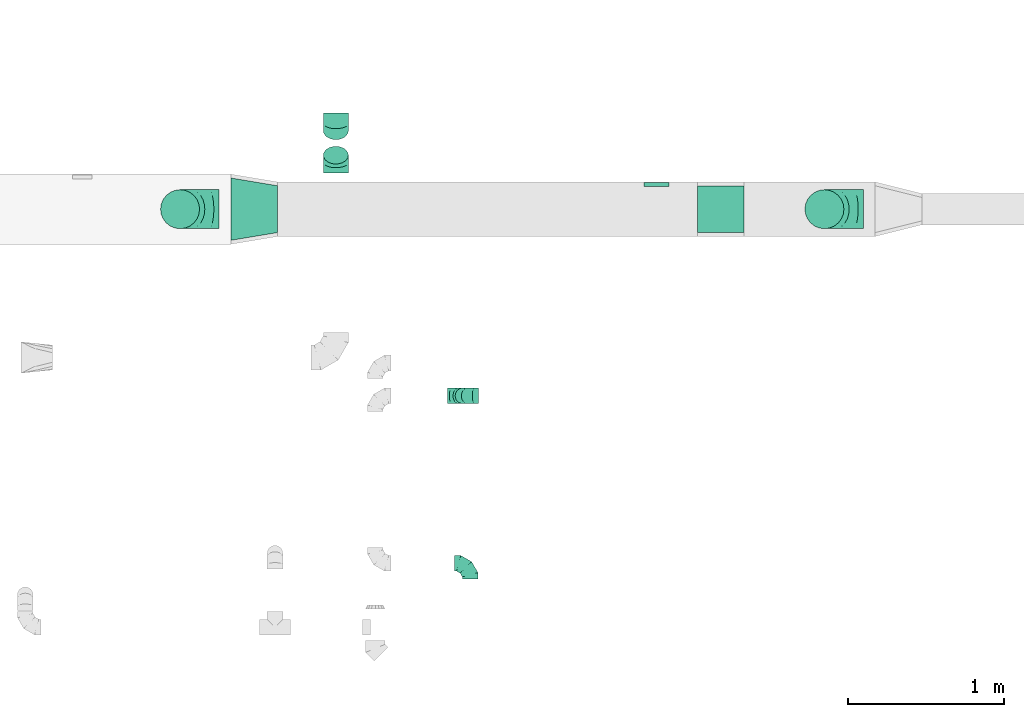
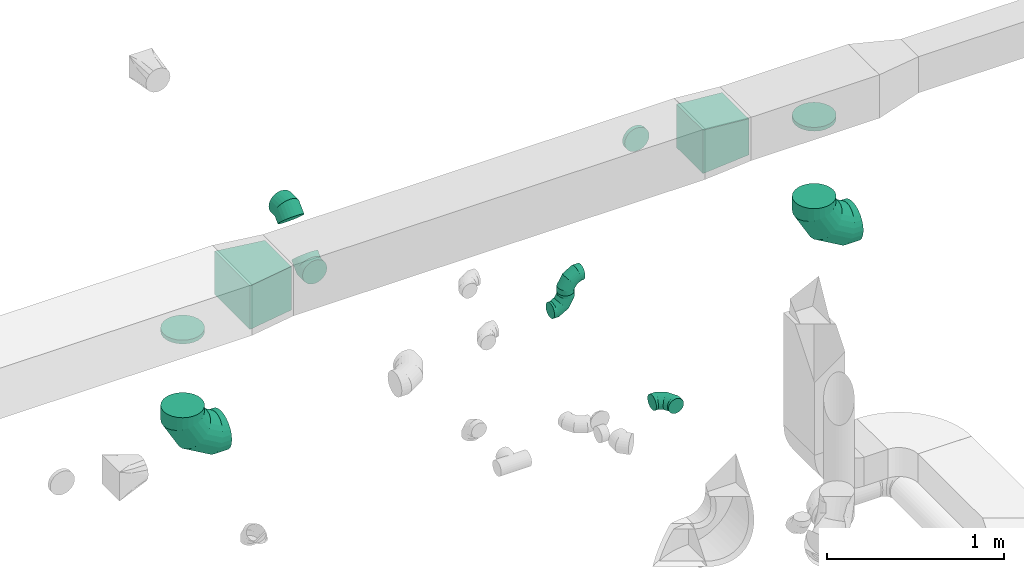
# One storey, part 70 of 97: 12 flow fittings.
"""IFC2X3 building model written with IfcOpenShell, lengths in millimetres."""

from ifc_helpers import new_model, entity, si_unit, converted_unit, derived_unit, direction, frame, origin, place, context, subcontext, project, spatial, polyline, outline, extrude, faceted_brep, source, transform, mapped, material, type_object, type_shapes, element, save


model = new_model("IFC2X3")

# Units and contexts
model_context = context("Model", 3, precision=0.01, world=origin(), true_north=direction((6.12303176911189e-17, 1.0)))
body_context = subcontext(model_context, "Body", "Model", "MODEL_VIEW")
ifc_project = project(units=[si_unit("LENGTHUNIT", "METRE", prefix="MILLI"), si_unit("AREAUNIT", "SQUARE_METRE"), si_unit("VOLUMEUNIT", "CUBIC_METRE"), converted_unit("PLANEANGLEUNIT", "DEGREE", entity("IfcRatioMeasure", 0.0174532925199433), si_unit("PLANEANGLEUNIT", "RADIAN"), dimensions=[0, 0, 0, 0, 0, 0, 0]), si_unit("MASSUNIT", "GRAM", prefix="KILO"), derived_unit("MASSDENSITYUNIT", [(si_unit("MASSUNIT", "GRAM", prefix="KILO"), 1), (si_unit("LENGTHUNIT", "METRE"), -3)]), derived_unit("MOMENTOFINERTIAUNIT", [(si_unit("LENGTHUNIT", "METRE"), 4)]), si_unit("TIMEUNIT", "SECOND"), si_unit("FREQUENCYUNIT", "HERTZ"), si_unit("THERMODYNAMICTEMPERATUREUNIT", "DEGREE_CELSIUS"), derived_unit("THERMALTRANSMITTANCEUNIT", [(si_unit("MASSUNIT", "GRAM", prefix="KILO"), 1), (si_unit("THERMODYNAMICTEMPERATUREUNIT", "KELVIN"), -1), (si_unit("TIMEUNIT", "SECOND"), -3)]), derived_unit("VOLUMETRICFLOWRATEUNIT", [(si_unit("LENGTHUNIT", "METRE"), 3), (si_unit("TIMEUNIT", "SECOND"), -1)]), derived_unit("MASSFLOWRATEUNIT", [(si_unit("MASSUNIT", "GRAM", prefix="KILO"), 1), (si_unit("TIMEUNIT", "SECOND"), -1)]), derived_unit("ROTATIONALFREQUENCYUNIT", [(si_unit("TIMEUNIT", "SECOND"), -1)]), si_unit("ELECTRICCURRENTUNIT", "AMPERE"), si_unit("ELECTRICVOLTAGEUNIT", "VOLT"), si_unit("POWERUNIT", "WATT"), si_unit("FORCEUNIT", "NEWTON", prefix="KILO"), si_unit("ILLUMINANCEUNIT", "LUX"), si_unit("LUMINOUSFLUXUNIT", "LUMEN"), si_unit("LUMINOUSINTENSITYUNIT", "CANDELA"), derived_unit("USERDEFINED", [(si_unit("MASSUNIT", "GRAM", prefix="KILO"), -1), (si_unit("LENGTHUNIT", "METRE"), -2), (si_unit("TIMEUNIT", "SECOND"), 3), (si_unit("LUMINOUSFLUXUNIT", "LUMEN"), 1)]), derived_unit("LINEARVELOCITYUNIT", [(si_unit("LENGTHUNIT", "METRE"), 1), (si_unit("TIMEUNIT", "SECOND"), -1)]), si_unit("PRESSUREUNIT", "PASCAL"), derived_unit("USERDEFINED", [(si_unit("LENGTHUNIT", "METRE"), -2), (si_unit("MASSUNIT", "GRAM", prefix="KILO"), 1), (si_unit("TIMEUNIT", "SECOND"), -2)]), derived_unit("LINEARFORCEUNIT", [(si_unit("MASSUNIT", "GRAM", prefix="KILO"), 1), (si_unit("LENGTHUNIT", "METRE"), 1), (si_unit("TIMEUNIT", "SECOND"), -2), (si_unit("LENGTHUNIT", "METRE"), -1)]), derived_unit("PLANARFORCEUNIT", [(si_unit("MASSUNIT", "GRAM", prefix="KILO"), 1), (si_unit("LENGTHUNIT", "METRE"), 1), (si_unit("TIMEUNIT", "SECOND"), -2), (si_unit("LENGTHUNIT", "METRE"), -2)])], contexts=[model_context])

# Site, building, storey
site_placement = place(None, origin())
site = spatial("IfcSite", under=ifc_project, at=site_placement, CompositionType="ELEMENT")
building_placement = place(site_placement, origin())
building = spatial("IfcBuilding", under=site, at=building_placement, CompositionType="ELEMENT")
storey_placement = place(building_placement, frame((0.0, 0.0, -4900.0)))
storey = spatial("IfcBuildingStorey", under=building, at=storey_placement, CompositionType="ELEMENT", Elevation=-4900.0)

# Flow fittings
ifc_material = material()
duct_fitting_type_1 = type_object("IfcDuctFittingType", PredefinedType="NOTDEFINED", material=ifc_material)
shared_shape_1 = source(origin(), body_context, "Body", "SweptSolid", [
    extrude(outline(polyline([(-180.84, -172.62), (123.3, -172.62), (172.62, 123.3), (-115.08, 221.94), (-180.84, -172.62)])), frame((150.0, 0.0, -150.0), z_axis=(0.0, 0.0, 1.0), x_axis=(0.986393923832144, 0.164398987305356, 0.0)), (0.0, 0.0, 1.0), 300.0),
])
type_shapes(duct_fitting_type_1, [shared_shape_1])
flow_fitting_1_placement = place(storey_placement, frame((57790.67, 15348.96, 4050.0)))
element("IfcFlowFitting", 1, at=flow_fitting_1_placement, inside=storey, type_object=duct_fitting_type_1, material=ifc_material, context=body_context, shape_type="MappedRepresentation", body=[
    mapped(shared_shape_1, transform((0.0, 0.0, 0.0), scale=1.0)),
])
duct_fitting_type_2 = type_object("IfcDuctFittingType", PredefinedType="NOTDEFINED", material=ifc_material)
shared_shape_2 = source(origin(), body_context, "Body", "SweptSolid", [
    extrude(outline(polyline([(-139.1, -137.03), (161.94, -137.03), (137.03, 161.94), (-159.86, 112.11), (-139.1, -137.03)])), frame((150.0, -150.0, 0.0), z_axis=(0.0, 1.0, 0.0), x_axis=(0.996545758244888, 0.0, 0.0830454798536443)), (0.0, 0.0, 1.0), 300.0),
])
type_shapes(duct_fitting_type_2, [shared_shape_2])
flow_fitting_2_placement = place(storey_placement, frame((61080.93, 15348.96, 4050.0), z_axis=(0.0, 0.0, 1.0), x_axis=(-1.0, 0.0, 0.0)))
element("IfcFlowFitting", 2, at=flow_fitting_2_placement, inside=storey, type_object=duct_fitting_type_2, material=ifc_material, context=body_context, shape_type="MappedRepresentation", body=[
    mapped(shared_shape_2, transform((0.0, 0.0, 0.0), scale=1.0)),
])
duct_fitting_type_3 = type_object("IfcDuctFittingType", PredefinedType="NOTDEFINED", material=ifc_material)
shared_shape_3 = source(origin(), body_context, "Body", "Brep", [
    faceted_brep([(-100.0, 0.0, -50.0), (-100.0, -12.94, -48.3), (-100.0, -25.0, -43.3), (-100.0, -35.36, -35.36), (-100.0, -43.3, -25.0), (-100.0, -48.3, -12.94), (-100.0, -50.0, 0.0), (-100.0, -48.3, 12.94), (-100.0, -43.3, 25.0), (-100.0, -35.36, 35.36), (-100.0, -25.0, 43.3), (-100.0, -12.94, 48.3), (-100.0, 0.0, 50.0), (-100.0, 12.94, 48.3), (-100.0, 25.0, 43.3), (-100.0, 35.36, 35.36), (-100.0, 43.3, 25.0), (-100.0, 48.3, 12.94), (-100.0, 50.0, 0.0), (-100.0, 48.3, -12.94), (-100.0, 43.3, -25.0), (-100.0, 35.36, -35.36), (-100.0, 25.0, -43.3), (-100.0, 12.94, -48.3), (-76.67, 12.94, 48.3), (-79.9, 25.0, 43.3), (-73.21, 0.0, 50.0), (-82.68, 35.36, 35.36), (-86.15, 48.3, 12.94), (-86.6, 50.0, 0.0), (-84.81, 43.3, 25.0), (-84.81, 43.3, -25.0), (-82.68, 35.36, -35.36), (-86.15, 48.3, -12.94), (-76.67, 12.94, -48.3), (-73.21, 0.0, -50.0), (-79.9, 25.0, -43.3), (-69.74, -12.94, -48.3), (-66.51, -25.0, -43.3), (-63.73, -35.36, -35.36), (-61.6, -43.3, -25.0), (-60.26, -48.3, -12.94), (-59.81, -50.0, 0.0), (-60.26, -48.3, 12.94), (-61.6, -43.3, 25.0), (-63.73, -35.36, 35.36), (-66.51, -25.0, 43.3), (-69.74, -12.94, 48.3), (-36.27, 36.27, 48.3), (-45.1, 45.1, 43.3), (-26.79, 26.79, 50.0), (-52.68, 52.68, 35.36), (-58.49, 58.49, 25.0), (-62.15, 62.15, 12.94), (-63.4, 63.4, 0.0), (-62.15, 62.15, -12.94), (-58.49, 58.49, -25.0), (-52.68, 52.68, -35.36), (-36.27, 36.27, -48.3), (-26.79, 26.79, -50.0), (-45.1, 45.1, -43.3), (-17.32, 17.32, -48.3), (-8.49, 8.49, -43.3), (-0.91, 0.91, -35.36), (4.9, -4.9, -25.0), (8.56, -8.56, -12.94), (9.81, -9.81, 0.0), (8.56, -8.56, 12.94), (4.9, -4.9, 25.0), (-0.91, 0.91, 35.36), (-8.49, 8.49, 43.3), (-17.32, 17.32, 48.3), (-12.94, 76.67, 48.3), (-25.0, 79.9, 43.3), (0.0, 73.21, 50.0), (-35.36, 82.68, 35.36), (-43.3, 84.81, 25.0), (-48.3, 86.15, 12.94), (-50.0, 86.6, 0.0), (-48.3, 86.15, -12.94), (-43.3, 84.81, -25.0), (-35.36, 82.68, -35.36), (-12.94, 76.67, -48.3), (0.0, 73.21, -50.0), (-25.0, 79.9, -43.3), (12.94, 69.74, -48.3), (25.0, 66.51, -43.3), (35.36, 63.73, -35.36), (43.3, 61.6, -25.0), (48.3, 60.26, -12.94), (50.0, 59.81, 0.0), (48.3, 60.26, 12.94), (43.3, 61.6, 25.0), (35.36, 63.73, 35.36), (25.0, 66.51, 43.3), (12.94, 69.74, 48.3), (-12.94, 100.0, -48.3), (-25.0, 100.0, -43.3), (-35.36, 100.0, -35.36), (-43.3, 100.0, -25.0), (-48.3, 100.0, -12.94), (-50.0, 100.0, 0.0), (-48.3, 100.0, 12.94), (-43.3, 100.0, 25.0), (-35.36, 100.0, 35.36), (-25.0, 100.0, 43.3), (-12.94, 100.0, 48.3), (0.0, 100.0, 50.0), (12.94, 100.0, 48.3), (25.0, 100.0, 43.3), (35.36, 100.0, 35.36), (43.3, 100.0, 25.0), (48.3, 100.0, 12.94), (50.0, 100.0, 0.0), (48.3, 100.0, -12.94), (43.3, 100.0, -25.0), (35.36, 100.0, -35.36), (25.0, 100.0, -43.3), (12.94, 100.0, -48.3), (0.0, 100.0, -50.0)], [[[0, 1, 2, 3, 4, 5, 6, 7, 8, 9, 10, 11, 12, 13, 14, 15, 16, 17, 18, 19, 20, 21, 22, 23]], [[24, 25, 14, 13]], [[26, 24, 13, 12]], [[14, 25, 27, 15]], [[28, 29, 18, 17]], [[30, 28, 17, 16]], [[15, 27, 30, 16]], [[20, 31, 32, 21]], [[33, 31, 20, 19]], [[18, 29, 33, 19]], [[34, 35, 0, 23]], [[36, 34, 23, 22]], [[32, 36, 22, 21]], [[2, 1, 37, 38]], [[3, 2, 38, 39]], [[0, 35, 37, 1]], [[5, 4, 40, 41]], [[6, 5, 41, 42]], [[3, 39, 40, 4]], [[6, 42, 43, 7]], [[7, 43, 44, 8]], [[8, 44, 45, 9]], [[10, 46, 47, 11]], [[11, 47, 26, 12]], [[10, 9, 45, 46]], [[48, 49, 25, 24]], [[50, 48, 24, 26]], [[27, 25, 49, 51]], [[52, 53, 28, 30]], [[51, 52, 30, 27]], [[29, 28, 53, 54]], [[55, 56, 31, 33]], [[54, 55, 33, 29]], [[57, 32, 31, 56]], [[58, 59, 35, 34]], [[60, 58, 34, 36]], [[57, 60, 36, 32]], [[37, 35, 59, 61]], [[38, 37, 61, 62]], [[39, 38, 62, 63]], [[41, 40, 64, 65]], [[42, 41, 65, 66]], [[63, 64, 40, 39]], [[43, 42, 66, 67]], [[44, 43, 67, 68]], [[68, 69, 45, 44]], [[46, 45, 69, 70]], [[47, 46, 70, 71]], [[26, 47, 71, 50]], [[72, 73, 49, 48]], [[74, 72, 48, 50]], [[51, 49, 73, 75]], [[76, 77, 53, 52]], [[75, 76, 52, 51]], [[54, 53, 77, 78]], [[79, 80, 56, 55]], [[78, 79, 55, 54]], [[81, 57, 56, 80]], [[82, 83, 59, 58]], [[84, 82, 58, 60]], [[81, 84, 60, 57]], [[61, 59, 83, 85]], [[62, 61, 85, 86]], [[63, 62, 86, 87]], [[65, 64, 88, 89]], [[66, 65, 89, 90]], [[87, 88, 64, 63]], [[67, 66, 90, 91]], [[68, 67, 91, 92]], [[92, 93, 69, 68]], [[70, 69, 93, 94]], [[71, 70, 94, 95]], [[50, 71, 95, 74]], [[96, 97, 98, 99, 100, 101, 102, 103, 104, 105, 106, 107, 108, 109, 110, 111, 112, 113, 114, 115, 116, 117, 118, 119]], [[72, 74, 107, 106]], [[73, 72, 106, 105]], [[75, 73, 105, 104]], [[77, 76, 103, 102]], [[78, 77, 102, 101]], [[75, 104, 103, 76]], [[78, 101, 100, 79]], [[79, 100, 99, 80]], [[80, 99, 98, 81]], [[96, 119, 83, 82]], [[97, 96, 82, 84]], [[84, 81, 98, 97]], [[83, 119, 118, 85]], [[85, 118, 117, 86]], [[86, 117, 116, 87]], [[88, 115, 114, 89]], [[89, 114, 113, 90]], [[87, 116, 115, 88]], [[91, 90, 113, 112]], [[92, 91, 112, 111]], [[93, 92, 111, 110]], [[95, 94, 109, 108]], [[74, 95, 108, 107]], [[110, 109, 94, 93]]]),
])
type_shapes(duct_fitting_type_3, [shared_shape_3])
for number, where, z_axis, x_axis in (
    (3, (59324.53, 13079.74, 4150.0), (0.0, 0.0, 1.0), (0.0, 1.0, 0.0)),
    (4, (59278.6, 14153.27, 4350.0), (0.0, -1.0, 0.0), (-1.0, 0.0, 0.0)),
    (5, (59278.6, 14153.27, 4150.0), (0.0, -1.0, 0.0), (1.0, 0.0, 0.0)),
):
    element("IfcFlowFitting", number, at=place(storey_placement, frame(where, z_axis=z_axis, x_axis=x_axis)), inside=storey, type_object=duct_fitting_type_3, material=ifc_material, context=body_context, shape_type="MappedRepresentation", body=[
        mapped(shared_shape_3, transform((0.0, 0.0, 0.0), scale=1.0)),
    ])
duct_fitting_type_4 = type_object("IfcDuctFittingType", PredefinedType="NOTDEFINED", material=ifc_material)
shared_shape_4 = source(origin(), body_context, "Body", "Brep", [
    faceted_brep([(-250.0, 0.0, -125.0), (-250.0, -32.35, -120.74), (-250.0, -62.5, -108.25), (-250.0, -88.39, -88.39), (-250.0, -108.25, -62.5), (-250.0, -120.74, -32.35), (-250.0, -125.0, 0.0), (-250.0, -120.74, 32.35), (-250.0, -108.25, 62.5), (-250.0, -88.39, 88.39), (-250.0, -62.5, 108.25), (-250.0, -32.35, 120.74), (-250.0, 0.0, 125.0), (-250.0, 32.35, 120.74), (-250.0, 62.5, 108.25), (-250.0, 88.39, 88.39), (-250.0, 108.25, 62.5), (-250.0, 120.74, 32.35), (-250.0, 125.0, 0.0), (-250.0, 120.74, -32.35), (-250.0, 108.25, -62.5), (-250.0, 88.39, -88.39), (-250.0, 62.5, -108.25), (-250.0, 32.35, -120.74), (-191.68, 32.35, 120.74), (-199.76, 62.5, 108.25), (-183.01, 0.0, 125.0), (-206.7, 88.39, 88.39), (-215.37, 120.74, 32.35), (-216.51, 125.0, 0.0), (-212.02, 108.25, 62.5), (-212.02, 108.25, -62.5), (-206.7, 88.39, -88.39), (-215.37, 120.74, -32.35), (-191.68, 32.35, -120.74), (-183.01, 0.0, -125.0), (-199.76, 62.5, -108.25), (-174.34, -32.35, -120.74), (-166.27, -62.5, -108.25), (-159.33, -88.39, -88.39), (-154.01, -108.25, -62.5), (-150.66, -120.74, -32.35), (-149.52, -125.0, 0.0), (-150.66, -120.74, 32.35), (-154.01, -108.25, 62.5), (-159.33, -88.39, 88.39), (-166.27, -62.5, 108.25), (-174.34, -32.35, 120.74), (-90.67, 90.67, 120.74), (-112.74, 112.74, 108.25), (-66.99, 66.99, 125.0), (-131.69, 131.69, 88.39), (-146.23, 146.23, 62.5), (-155.38, 155.38, 32.35), (-158.49, 158.49, 0.0), (-155.38, 155.38, -32.35), (-146.23, 146.23, -62.5), (-131.69, 131.69, -88.39), (-90.67, 90.67, -120.74), (-66.99, 66.99, -125.0), (-112.74, 112.74, -108.25), (-43.3, 43.3, -120.74), (-21.23, 21.23, -108.25), (-2.28, 2.28, -88.39), (12.26, -12.26, -62.5), (21.4, -21.4, -32.35), (24.52, -24.52, 0.0), (21.4, -21.4, 32.35), (12.26, -12.26, 62.5), (-2.28, 2.28, 88.39), (-21.23, 21.23, 108.25), (-43.3, 43.3, 120.74), (-32.35, 191.68, 120.74), (-62.5, 199.76, 108.25), (0.0, 183.01, 125.0), (-88.39, 206.7, 88.39), (-108.25, 212.02, 62.5), (-120.74, 215.37, 32.35), (-125.0, 216.51, 0.0), (-120.74, 215.37, -32.35), (-108.25, 212.02, -62.5), (-88.39, 206.7, -88.39), (-32.35, 191.68, -120.74), (0.0, 183.01, -125.0), (-62.5, 199.76, -108.25), (32.35, 174.34, -120.74), (62.5, 166.27, -108.25), (88.39, 159.33, -88.39), (108.25, 154.01, -62.5), (120.74, 150.66, -32.35), (125.0, 149.52, 0.0), (120.74, 150.66, 32.35), (108.25, 154.01, 62.5), (88.39, 159.33, 88.39), (62.5, 166.27, 108.25), (32.35, 174.34, 120.74), (-32.35, 250.0, -120.74), (-62.5, 250.0, -108.25), (-88.39, 250.0, -88.39), (-108.25, 250.0, -62.5), (-120.74, 250.0, -32.35), (-125.0, 250.0, 0.0), (-120.74, 250.0, 32.35), (-108.25, 250.0, 62.5), (-88.39, 250.0, 88.39), (-62.5, 250.0, 108.25), (-32.35, 250.0, 120.74), (0.0, 250.0, 125.0), (32.35, 250.0, 120.74), (62.5, 250.0, 108.25), (88.39, 250.0, 88.39), (108.25, 250.0, 62.5), (120.74, 250.0, 32.35), (125.0, 250.0, 0.0), (120.74, 250.0, -32.35), (108.25, 250.0, -62.5), (88.39, 250.0, -88.39), (62.5, 250.0, -108.25), (32.35, 250.0, -120.74), (0.0, 250.0, -125.0)], [[[0, 1, 2, 3, 4, 5, 6, 7, 8, 9, 10, 11, 12, 13, 14, 15, 16, 17, 18, 19, 20, 21, 22, 23]], [[24, 25, 14, 13]], [[26, 24, 13, 12]], [[14, 25, 27, 15]], [[28, 29, 18, 17]], [[30, 28, 17, 16]], [[15, 27, 30, 16]], [[20, 31, 32, 21]], [[33, 31, 20, 19]], [[18, 29, 33, 19]], [[34, 35, 0, 23]], [[36, 34, 23, 22]], [[21, 32, 36, 22]], [[1, 0, 35, 37]], [[2, 1, 37, 38]], [[38, 39, 3, 2]], [[5, 4, 40, 41]], [[6, 5, 41, 42]], [[39, 40, 4, 3]], [[6, 42, 43, 7]], [[7, 43, 44, 8]], [[8, 44, 45, 9]], [[9, 45, 46, 10]], [[10, 46, 47, 11]], [[26, 12, 11, 47]], [[48, 49, 25, 24]], [[50, 48, 24, 26]], [[27, 25, 49, 51]], [[52, 53, 28, 30]], [[51, 52, 30, 27]], [[29, 28, 53, 54]], [[55, 56, 31, 33]], [[54, 55, 33, 29]], [[32, 31, 56, 57]], [[58, 59, 35, 34]], [[60, 58, 34, 36]], [[57, 60, 36, 32]], [[37, 35, 59, 61]], [[38, 37, 61, 62]], [[39, 38, 62, 63]], [[41, 40, 64, 65]], [[42, 41, 65, 66]], [[63, 64, 40, 39]], [[43, 42, 66, 67]], [[44, 43, 67, 68]], [[68, 69, 45, 44]], [[46, 45, 69, 70]], [[47, 46, 70, 71]], [[26, 47, 71, 50]], [[72, 73, 49, 48]], [[74, 72, 48, 50]], [[51, 49, 73, 75]], [[76, 77, 53, 52]], [[75, 76, 52, 51]], [[54, 53, 77, 78]], [[79, 80, 56, 55]], [[78, 79, 55, 54]], [[57, 56, 80, 81]], [[82, 83, 59, 58]], [[84, 82, 58, 60]], [[81, 84, 60, 57]], [[61, 59, 83, 85]], [[62, 61, 85, 86]], [[63, 62, 86, 87]], [[65, 64, 88, 89]], [[66, 65, 89, 90]], [[87, 88, 64, 63]], [[67, 66, 90, 91]], [[68, 67, 91, 92]], [[92, 93, 69, 68]], [[70, 69, 93, 94]], [[71, 70, 94, 95]], [[50, 71, 95, 74]], [[96, 97, 98, 99, 100, 101, 102, 103, 104, 105, 106, 107, 108, 109, 110, 111, 112, 113, 114, 115, 116, 117, 118, 119]], [[72, 74, 107, 106]], [[73, 72, 106, 105]], [[75, 73, 105, 104]], [[77, 76, 103, 102]], [[78, 77, 102, 101]], [[75, 104, 103, 76]], [[78, 101, 100, 79]], [[79, 100, 99, 80]], [[80, 99, 98, 81]], [[84, 97, 96, 82]], [[82, 96, 119, 83]], [[84, 81, 98, 97]], [[83, 119, 118, 85]], [[85, 118, 117, 86]], [[116, 87, 86, 117]], [[88, 115, 114, 89]], [[89, 114, 113, 90]], [[115, 88, 87, 116]], [[91, 90, 113, 112]], [[92, 91, 112, 111]], [[111, 110, 93, 92]], [[95, 94, 109, 108]], [[74, 95, 108, 107]], [[110, 109, 94, 93]]]),
])
type_shapes(duct_fitting_type_4, [shared_shape_4])
for number, where, z_axis, x_axis in (
    (6, (57465.82, 15348.96, 3120.0), (0.0, 1.0, 0.0), (-1.0, 0.0, 0.0)),
    (7, (61595.08, 15348.96, 3120.0), (0.0, 1.0, 0.0), (-1.0, 0.0, 0.0)),
):
    element("IfcFlowFitting", number, at=place(storey_placement, frame(where, z_axis=z_axis, x_axis=x_axis)), inside=storey, type_object=duct_fitting_type_4, material=ifc_material, context=body_context, shape_type="MappedRepresentation", body=[
        mapped(shared_shape_4, transform((0.0, 0.0, 0.0), scale=1.0)),
    ])
duct_fitting_type_5 = type_object("IfcDuctFittingType", PredefinedType="NOTDEFINED", material=ifc_material)
shared_shape_5 = source(origin(), body_context, "Body", "Brep", [
    faceted_brep([(20.0, 0.0, -125.0), (20.0, 32.35, -120.74), (20.0, 62.5, -108.25), (20.0, 88.39, -88.39), (20.0, 108.25, -62.5), (20.0, 120.74, -32.35), (20.0, 125.0, 0.0), (20.0, 120.74, 32.35), (20.0, 108.25, 62.5), (20.0, 88.39, 88.39), (20.0, 62.5, 108.25), (20.0, 32.35, 120.74), (20.0, 0.0, 125.0), (20.0, -32.35, 120.74), (20.0, -62.5, 108.25), (20.0, -88.39, 88.39), (20.0, -108.25, 62.5), (20.0, -120.74, 32.35), (20.0, -125.0, 0.0), (20.0, -120.74, -32.35), (20.0, -108.25, -62.5), (20.0, -88.39, -88.39), (20.0, -62.5, -108.25), (20.0, -32.35, -120.74), (0.0, 0.0, 125.0), (-6.1, 0.0, 125.0), (-6.1, -32.35, 120.74), (0.0, -32.35, 120.74), (-6.1, -62.5, 108.25), (0.0, -62.5, 108.25), (0.0, -88.39, 88.39), (-6.1, -88.39, 88.39), (0.0, -108.25, 62.5), (-6.1, -108.25, 62.5), (-6.1, -120.74, 32.35), (0.0, -120.74, 32.35), (-6.1, -125.0, 0.0), (0.0, -125.0, 0.0), (-6.1, -120.74, -32.35), (0.0, -120.74, -32.35), (-6.1, -108.25, -62.5), (0.0, -108.25, -62.5), (0.0, -88.39, -88.39), (-6.1, -88.39, -88.39), (0.0, -62.5, -108.25), (-6.1, -62.5, -108.25), (-6.1, -32.35, -120.74), (0.0, -32.35, -120.74), (-6.1, 0.0, -125.0), (0.0, 0.0, -125.0), (-6.1, 32.35, -120.74), (0.0, 32.35, -120.74), (-6.1, 62.5, -108.25), (0.0, 62.5, -108.25), (0.0, 88.39, -88.39), (-6.1, 88.39, -88.39), (0.0, 108.25, -62.5), (-6.1, 108.25, -62.5), (-6.1, 120.74, -32.35), (0.0, 120.74, -32.35), (-6.1, 125.0, 0.0), (0.0, 125.0, 0.0), (-6.1, 120.74, 32.35), (0.0, 120.74, 32.35), (-6.1, 108.25, 62.5), (0.0, 108.25, 62.5), (0.0, 88.39, 88.39), (-6.1, 88.39, 88.39), (0.0, 62.5, 108.25), (-6.1, 62.5, 108.25), (-6.1, 32.35, 120.74), (0.0, 32.35, 120.74)], [[[0, 1, 2, 3, 4, 5, 6, 7, 8, 9, 10, 11, 12, 13, 14, 15, 16, 17, 18, 19, 20, 21, 22, 23]], [[13, 12, 24, 25, 26, 27]], [[14, 13, 27, 26, 28, 29]], [[30, 15, 14, 29, 28, 31]], [[17, 16, 32, 33, 34, 35]], [[18, 17, 35, 34, 36, 37]], [[32, 16, 15, 30, 31, 33]], [[19, 18, 37, 36, 38, 39]], [[20, 19, 39, 38, 40, 41]], [[42, 21, 20, 41, 40, 43]], [[23, 22, 44, 45, 46, 47]], [[0, 23, 47, 46, 48, 49]], [[44, 22, 21, 42, 43, 45]], [[1, 0, 49, 48, 50, 51]], [[2, 1, 51, 50, 52, 53]], [[54, 3, 2, 53, 52, 55]], [[5, 4, 56, 57, 58, 59]], [[6, 5, 59, 58, 60, 61]], [[56, 4, 3, 54, 55, 57]], [[7, 6, 61, 60, 62, 63]], [[8, 7, 63, 62, 64, 65]], [[66, 9, 8, 65, 64, 67]], [[11, 10, 68, 69, 70, 71]], [[12, 11, 71, 70, 25, 24]], [[68, 10, 9, 66, 67, 69]], [[46, 45, 43, 40, 38, 36, 34, 33, 31, 28, 26, 25, 70, 69, 67, 64, 62, 60, 58, 57, 55, 52, 50, 48]]]),
])
type_shapes(duct_fitting_type_5, [shared_shape_5])
flow_fitting_3_placement = place(storey_placement, frame((57465.82, 15348.96, 3900.0), z_axis=(0.0, -1.0, 0.0), x_axis=(0.0, 0.0, -1.0)))
element("IfcFlowFitting", 8, at=flow_fitting_3_placement, inside=storey, type_object=duct_fitting_type_5, material=ifc_material, context=body_context, shape_type="MappedRepresentation", body=[
    mapped(shared_shape_5, transform((0.0, 0.0, 0.0), scale=1.0)),
])
duct_fitting_type_6 = type_object("IfcDuctFittingType", PredefinedType="NOTDEFINED", material=ifc_material)
shared_shape_6 = source(origin(), body_context, "Body", "Brep", [
    faceted_brep([(20.0, 32.35, -120.74), (20.0, 62.5, -108.25), (20.0, 88.39, -88.39), (20.0, 108.25, -62.5), (20.0, 120.74, -32.35), (20.0, 125.0, 0.0), (20.0, 120.74, 32.35), (20.0, 108.25, 62.5), (20.0, 88.39, 88.39), (20.0, 62.5, 108.25), (20.0, 32.35, 120.74), (20.0, 0.0, 125.0), (20.0, -32.35, 120.74), (20.0, -62.5, 108.25), (20.0, -88.39, 88.39), (20.0, -108.25, 62.5), (20.0, -120.74, 32.35), (20.0, -125.0, 0.0), (20.0, -120.74, -32.35), (20.0, -108.25, -62.5), (20.0, -88.39, -88.39), (20.0, -62.5, -108.25), (20.0, -32.35, -120.74), (20.0, 0.0, -125.0), (0.0, 0.0, 125.0), (0.0, 32.35, 120.74), (-6.1, 32.35, 120.74), (-6.1, 0.0, 125.0), (0.0, 62.5, 108.25), (-6.1, 62.5, 108.25), (0.0, 88.39, 88.39), (-6.1, 88.39, 88.39), (0.0, 108.25, 62.5), (0.0, 120.74, 32.35), (-6.1, 120.74, 32.35), (-6.1, 108.25, 62.5), (0.0, 125.0, 0.0), (-6.1, 125.0, 0.0), (0.0, 120.74, -32.35), (-6.1, 120.74, -32.35), (0.0, 108.25, -62.5), (-6.1, 108.25, -62.5), (0.0, 88.39, -88.39), (-6.1, 88.39, -88.39), (0.0, 62.5, -108.25), (0.0, 32.35, -120.74), (-6.1, 32.35, -120.74), (-6.1, 62.5, -108.25), (0.0, 0.0, -125.0), (-6.1, 0.0, -125.0), (0.0, -32.35, -120.74), (-6.1, -32.35, -120.74), (0.0, -62.5, -108.25), (-6.1, -62.5, -108.25), (0.0, -88.39, -88.39), (-6.1, -88.39, -88.39), (0.0, -108.25, -62.5), (0.0, -120.74, -32.35), (-6.1, -120.74, -32.35), (-6.1, -108.25, -62.5), (0.0, -125.0, 0.0), (-6.1, -125.0, 0.0), (0.0, -120.74, 32.35), (-6.1, -120.74, 32.35), (0.0, -108.25, 62.5), (-6.1, -108.25, 62.5), (0.0, -88.39, 88.39), (-6.1, -88.39, 88.39), (0.0, -62.5, 108.25), (0.0, -32.35, 120.74), (-6.1, -32.35, 120.74), (-6.1, -62.5, 108.25)], [[[0, 1, 2, 3, 4, 5, 6, 7, 8, 9, 10, 11, 12, 13, 14, 15, 16, 17, 18, 19, 20, 21, 22, 23]], [[24, 11, 10, 25, 26, 27]], [[25, 10, 9, 28, 29, 26]], [[28, 9, 8, 30, 31, 29]], [[32, 7, 6, 33, 34, 35]], [[33, 6, 5, 36, 37, 34]], [[30, 8, 7, 32, 35, 31]], [[36, 5, 4, 38, 39, 37]], [[38, 4, 3, 40, 41, 39]], [[40, 3, 2, 42, 43, 41]], [[44, 1, 0, 45, 46, 47]], [[45, 0, 23, 48, 49, 46]], [[42, 2, 1, 44, 47, 43]], [[48, 23, 22, 50, 51, 49]], [[50, 22, 21, 52, 53, 51]], [[52, 21, 20, 54, 55, 53]], [[56, 19, 18, 57, 58, 59]], [[57, 18, 17, 60, 61, 58]], [[54, 20, 19, 56, 59, 55]], [[60, 17, 16, 62, 63, 61]], [[62, 16, 15, 64, 65, 63]], [[64, 15, 14, 66, 67, 65]], [[68, 13, 12, 69, 70, 71]], [[69, 12, 11, 24, 27, 70]], [[66, 14, 13, 68, 71, 67]], [[49, 51, 53, 55, 59, 58, 61, 63, 65, 67, 71, 70, 27, 26, 29, 31, 35, 34, 37, 39, 41, 43, 47, 46]]]),
])
type_shapes(duct_fitting_type_6, [shared_shape_6])
flow_fitting_4_placement = place(storey_placement, frame((61595.08, 15348.96, 3925.0), z_axis=(0.0, 1.0, 0.0), x_axis=(0.0, 0.0, -1.0)))
element("IfcFlowFitting", 9, at=flow_fitting_4_placement, inside=storey, type_object=duct_fitting_type_6, material=ifc_material, context=body_context, shape_type="MappedRepresentation", body=[
    mapped(shared_shape_6, transform((0.0, 0.0, 0.0), scale=1.0)),
])
duct_fitting_type_7 = type_object("IfcDuctFittingType", PredefinedType="NOTDEFINED", material=ifc_material)
shared_shape_7 = source(origin(), body_context, "Body", "Brep", [
    faceted_brep([(20.0, 0.0, -80.0), (20.0, 20.71, -77.27), (20.0, 40.0, -69.28), (20.0, 56.57, -56.57), (20.0, 69.28, -40.0), (20.0, 77.27, -20.71), (20.0, 80.0, 0.0), (20.0, 77.27, 20.71), (20.0, 69.28, 40.0), (20.0, 56.57, 56.57), (20.0, 40.0, 69.28), (20.0, 20.71, 77.27), (20.0, 0.0, 80.0), (20.0, -20.71, 77.27), (20.0, -40.0, 69.28), (20.0, -56.57, 56.57), (20.0, -69.28, 40.0), (20.0, -77.27, 20.71), (20.0, -80.0, 0.0), (20.0, -77.27, -20.71), (20.0, -69.28, -40.0), (20.0, -56.57, -56.57), (20.0, -40.0, -69.28), (20.0, -20.71, -77.27), (0.0, 0.0, 80.0), (-6.1, 0.0, 80.0), (-6.1, -20.71, 77.27), (0.0, -20.71, 77.27), (-6.1, -40.0, 69.28), (0.0, -40.0, 69.28), (0.0, -56.57, 56.57), (-6.1, -56.57, 56.57), (0.0, -69.28, 40.0), (-6.1, -69.28, 40.0), (-6.1, -77.27, 20.71), (0.0, -77.27, 20.71), (-6.1, -80.0, 0.0), (0.0, -80.0, 0.0), (-6.1, -77.27, -20.71), (0.0, -77.27, -20.71), (-6.1, -69.28, -40.0), (0.0, -69.28, -40.0), (0.0, -56.57, -56.57), (-6.1, -56.57, -56.57), (0.0, -40.0, -69.28), (-6.1, -40.0, -69.28), (-6.1, -20.71, -77.27), (0.0, -20.71, -77.27), (-6.1, 0.0, -80.0), (0.0, 0.0, -80.0), (-6.1, 20.71, -77.27), (0.0, 20.71, -77.27), (-6.1, 40.0, -69.28), (0.0, 40.0, -69.28), (0.0, 56.57, -56.57), (-6.1, 56.57, -56.57), (0.0, 69.28, -40.0), (-6.1, 69.28, -40.0), (-6.1, 77.27, -20.71), (0.0, 77.27, -20.71), (-6.1, 80.0, 0.0), (0.0, 80.0, 0.0), (-6.1, 77.27, 20.71), (0.0, 77.27, 20.71), (-6.1, 69.28, 40.0), (0.0, 69.28, 40.0), (0.0, 56.57, 56.57), (-6.1, 56.57, 56.57), (0.0, 40.0, 69.28), (-6.1, 40.0, 69.28), (-6.1, 20.71, 77.27), (0.0, 20.71, 77.27)], [[[0, 1, 2, 3, 4, 5, 6, 7, 8, 9, 10, 11, 12, 13, 14, 15, 16, 17, 18, 19, 20, 21, 22, 23]], [[13, 12, 24, 25, 26, 27]], [[14, 13, 27, 26, 28, 29]], [[30, 15, 14, 29, 28, 31]], [[17, 16, 32, 33, 34, 35]], [[18, 17, 35, 34, 36, 37]], [[32, 16, 15, 30, 31, 33]], [[19, 18, 37, 36, 38, 39]], [[20, 19, 39, 38, 40, 41]], [[42, 21, 20, 41, 40, 43]], [[23, 22, 44, 45, 46, 47]], [[0, 23, 47, 46, 48, 49]], [[44, 22, 21, 42, 43, 45]], [[1, 0, 49, 48, 50, 51]], [[2, 1, 51, 50, 52, 53]], [[54, 3, 2, 53, 52, 55]], [[5, 4, 56, 57, 58, 59]], [[6, 5, 59, 58, 60, 61]], [[56, 4, 3, 54, 55, 57]], [[7, 6, 61, 60, 62, 63]], [[8, 7, 63, 62, 64, 65]], [[66, 9, 8, 65, 64, 67]], [[11, 10, 68, 69, 70, 71]], [[12, 11, 71, 70, 25, 24]], [[68, 10, 9, 66, 67, 69]], [[46, 45, 43, 40, 38, 36, 34, 33, 31, 28, 26, 25, 70, 69, 67, 64, 62, 60, 58, 57, 55, 52, 50, 48]]]),
])
type_shapes(duct_fitting_type_7, [shared_shape_7])
flow_fitting_5_placement = place(storey_placement, frame((60519.38, 15498.96, 4050.0), z_axis=(0.0, 0.0, -1.0), x_axis=(0.0, 1.0, 0.0)))
element("IfcFlowFitting", 10, at=flow_fitting_5_placement, inside=storey, type_object=duct_fitting_type_7, material=ifc_material, context=body_context, shape_type="MappedRepresentation", body=[
    mapped(shared_shape_7, transform((0.0, 0.0, 0.0), scale=1.0)),
])
duct_fitting_type_8 = type_object("IfcDuctFittingType", PredefinedType="NOTDEFINED", material=ifc_material)
shared_shape_8 = source(origin(), body_context, "Body", "Brep", [
    faceted_brep([(-66.27, 0.0, -80.0), (-66.27, -20.71, -77.27), (-66.27, -40.0, -69.28), (-66.27, -56.57, -56.57), (-66.27, -69.28, -40.0), (-66.27, -77.27, -20.71), (-66.27, -80.0, 0.0), (-66.27, -77.27, 20.71), (-66.27, -69.28, 40.0), (-66.27, -56.57, 56.57), (-66.27, -40.0, 69.28), (-66.27, -20.71, 77.27), (-66.27, 0.0, 80.0), (-66.27, 20.71, 77.27), (-66.27, 40.0, 69.28), (-66.27, 56.57, 56.57), (-66.27, 69.28, 40.0), (-66.27, 77.27, 20.71), (-66.27, 80.0, 0.0), (-66.27, 77.27, -20.71), (-66.27, 69.28, -40.0), (-66.27, 56.57, -56.57), (-66.27, 40.0, -69.28), (-66.27, 20.71, -77.27), (-8.58, 20.71, 77.27), (-16.57, 40.0, 69.28), (0.0, 0.0, 80.0), (-23.43, 56.57, 56.57), (-28.7, 69.28, 40.0), (-32.01, 77.27, 20.71), (-33.14, 80.0, 0.0), (-32.01, 77.27, -20.71), (-28.7, 69.28, -40.0), (-23.43, 56.57, -56.57), (-8.58, 20.71, -77.27), (0.0, 0.0, -80.0), (-16.57, 40.0, -69.28), (8.58, -20.71, -77.27), (16.57, -40.0, -69.28), (23.43, -56.57, -56.57), (28.7, -69.28, -40.0), (32.01, -77.27, -20.71), (33.14, -80.0, 0.0), (32.01, -77.27, 20.71), (28.7, -69.28, 40.0), (23.43, -56.57, 56.57), (16.57, -40.0, 69.28), (8.58, -20.71, 77.27), (46.86, 46.86, 80.0), (32.22, 61.5, 77.27), (18.58, 75.15, 69.28), (6.86, 86.86, 56.57), (-2.13, 95.85, 40.0), (-7.78, 101.5, 20.71), (-9.71, 103.43, 0.0), (-7.78, 101.5, -20.71), (-2.13, 95.85, -40.0), (6.86, 86.86, -56.57), (18.58, 75.15, -69.28), (32.22, 61.5, -77.27), (46.86, 46.86, -80.0), (61.5, 32.22, -77.27), (75.15, 18.58, -69.28), (86.86, 6.86, -56.57), (95.85, -2.13, -40.0), (101.5, -7.78, -20.71), (103.43, -9.71, 0.0), (101.5, -7.78, 20.71), (95.85, -2.13, 40.0), (86.86, 6.86, 56.57), (75.15, 18.58, 69.28), (61.5, 32.22, 77.27)], [[[0, 1, 2, 3, 4, 5, 6, 7, 8, 9, 10, 11, 12, 13, 14, 15, 16, 17, 18, 19, 20, 21, 22, 23]], [[24, 25, 14, 13]], [[26, 24, 13, 12]], [[14, 25, 27, 15]], [[28, 29, 17, 16]], [[28, 16, 15, 27]], [[30, 18, 17, 29]], [[31, 32, 20, 19]], [[30, 31, 19, 18]], [[32, 33, 21, 20]], [[34, 35, 0, 23]], [[36, 34, 23, 22]], [[33, 36, 22, 21]], [[1, 0, 35, 37]], [[2, 1, 37, 38]], [[38, 39, 3, 2]], [[5, 4, 40, 41]], [[6, 5, 41, 42]], [[39, 40, 4, 3]], [[6, 42, 43, 7]], [[7, 43, 44, 8]], [[8, 44, 45, 9]], [[9, 45, 46, 10]], [[10, 46, 47, 11]], [[26, 12, 11, 47]], [[24, 26, 48, 49]], [[25, 24, 49, 50]], [[27, 25, 50, 51]], [[29, 28, 52, 53]], [[30, 29, 53, 54]], [[51, 52, 28, 27]], [[30, 54, 55, 31]], [[31, 55, 56, 32]], [[57, 33, 32, 56]], [[36, 58, 59, 34]], [[34, 59, 60, 35]], [[58, 36, 33, 57]], [[35, 60, 61, 37]], [[37, 61, 62, 38]], [[63, 39, 38, 62]], [[40, 64, 65, 41]], [[41, 65, 66, 42]], [[64, 40, 39, 63]], [[43, 42, 66, 67]], [[44, 43, 67, 68]], [[68, 69, 45, 44]], [[47, 46, 70, 71]], [[26, 47, 71, 48]], [[69, 70, 46, 45]], [[59, 58, 57, 56, 55, 54, 53, 52, 51, 50, 49, 48, 71, 70, 69, 68, 67, 66, 65, 64, 63, 62, 61, 60]]]),
])
type_shapes(duct_fitting_type_8, [shared_shape_8])
flow_fitting_6_placement = place(storey_placement, frame((58464.14, 15898.25, 4050.0), z_axis=(1.0, 0.0, 0.0), x_axis=(0.0, -1.0, -1.58396346890977e-08)))
element("IfcFlowFitting", 11, at=flow_fitting_6_placement, inside=storey, type_object=duct_fitting_type_8, material=ifc_material, context=body_context, shape_type="MappedRepresentation", body=[
    mapped(shared_shape_8, transform((0.0, 0.0, 0.0), scale=1.0)),
])
duct_fitting_type_9 = type_object("IfcDuctFittingType", PredefinedType="NOTDEFINED", material=ifc_material)
type_shapes(duct_fitting_type_9, [shared_shape_8])
flow_fitting_7_placement = place(storey_placement, frame((58464.14, 15648.25, 3800.0), z_axis=(-1.0, 0.0, 0.0), x_axis=(0.0, -0.707106781186493, -0.707106781186602)))
element("IfcFlowFitting", 12, at=flow_fitting_7_placement, inside=storey, type_object=duct_fitting_type_9, material=ifc_material, context=body_context, shape_type="MappedRepresentation", body=[
    mapped(shared_shape_8, transform((0.0, 0.0, 0.0), scale=1.0)),
])

save(model, "model.ifc")
